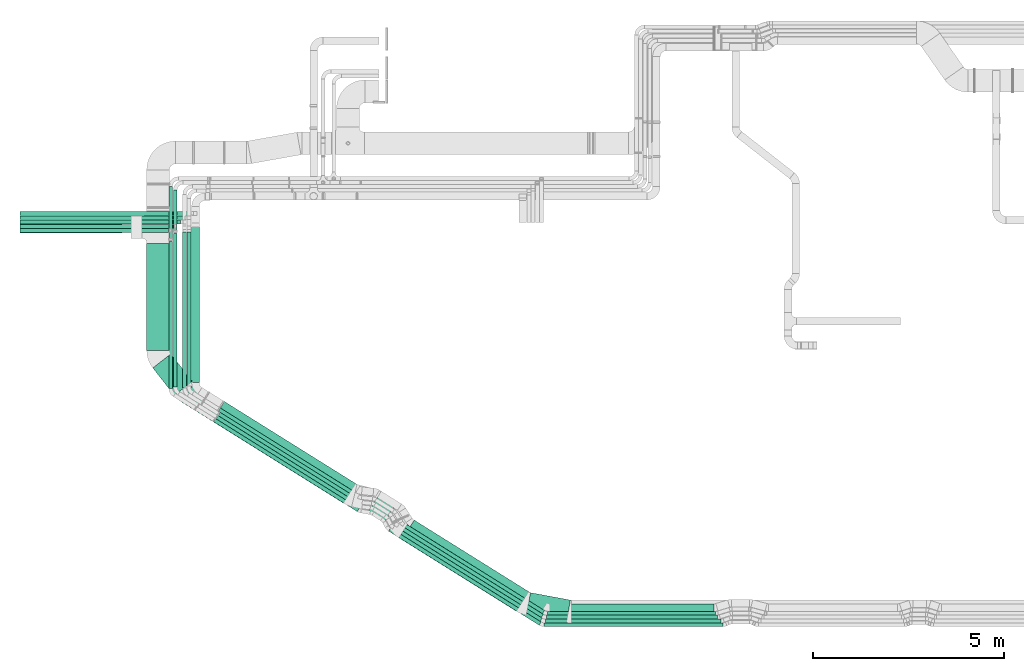
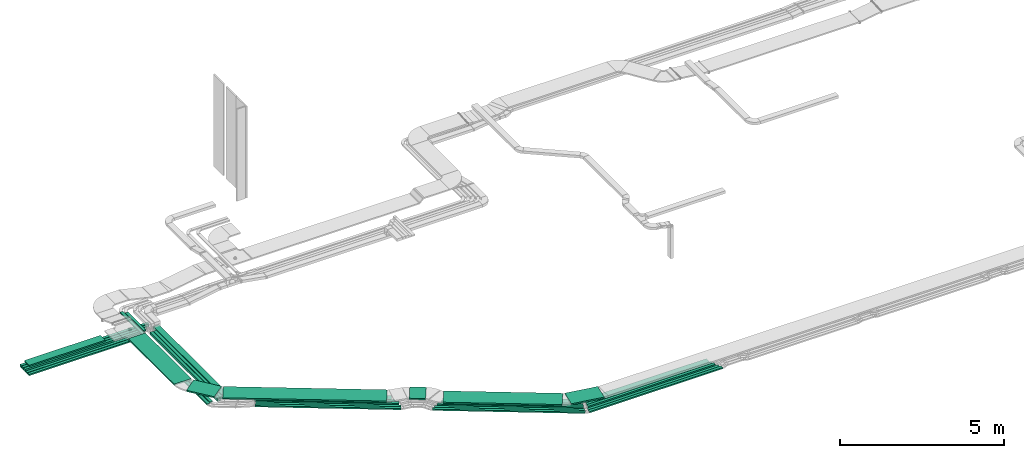
# One storey, part 1 of 28: 34 flow segments.
"""IFC2X3 building model written with IfcOpenShell, lengths in millimetres."""

from ifc_helpers import new_model, entity, si_unit, converted_unit, derived_unit, direction, frame, origin, origin_2d_with_axis, place, context, subcontext, project, spatial, rectangle, extrude, type_object, element, save


model = new_model("IFC2X3")

# Units and contexts
model_context = context("Model", 3, precision=0.01, world=origin(), true_north=direction((6.12303176911189e-17, 1.0)))
body_context = subcontext(model_context, "Body", "Model", "MODEL_VIEW")
ifc_project = project(units=[si_unit("LENGTHUNIT", "METRE", prefix="MILLI"), si_unit("AREAUNIT", "SQUARE_METRE"), si_unit("VOLUMEUNIT", "CUBIC_METRE"), converted_unit("PLANEANGLEUNIT", "DEGREE", entity("IfcRatioMeasure", 0.0174532925199433), si_unit("PLANEANGLEUNIT", "RADIAN"), dimensions=[0, 0, 0, 0, 0, 0, 0]), si_unit("MASSUNIT", "GRAM", prefix="KILO"), derived_unit("MASSDENSITYUNIT", [(si_unit("MASSUNIT", "GRAM", prefix="KILO"), 1), (si_unit("LENGTHUNIT", "METRE"), -3)]), derived_unit("MOMENTOFINERTIAUNIT", [(si_unit("LENGTHUNIT", "METRE"), 4)]), si_unit("TIMEUNIT", "SECOND"), si_unit("FREQUENCYUNIT", "HERTZ"), si_unit("THERMODYNAMICTEMPERATUREUNIT", "DEGREE_CELSIUS"), derived_unit("THERMALTRANSMITTANCEUNIT", [(si_unit("MASSUNIT", "GRAM", prefix="KILO"), 1), (si_unit("THERMODYNAMICTEMPERATUREUNIT", "KELVIN"), -1), (si_unit("TIMEUNIT", "SECOND"), -3)]), derived_unit("VOLUMETRICFLOWRATEUNIT", [(si_unit("LENGTHUNIT", "METRE"), 3), (si_unit("TIMEUNIT", "SECOND"), -1)]), derived_unit("MASSFLOWRATEUNIT", [(si_unit("MASSUNIT", "GRAM", prefix="KILO"), 1), (si_unit("TIMEUNIT", "SECOND"), -1)]), derived_unit("ROTATIONALFREQUENCYUNIT", [(si_unit("TIMEUNIT", "SECOND"), -1)]), si_unit("ELECTRICCURRENTUNIT", "AMPERE"), si_unit("ELECTRICVOLTAGEUNIT", "VOLT"), si_unit("POWERUNIT", "WATT"), si_unit("FORCEUNIT", "NEWTON", prefix="KILO"), si_unit("ILLUMINANCEUNIT", "LUX"), si_unit("LUMINOUSFLUXUNIT", "LUMEN"), si_unit("LUMINOUSINTENSITYUNIT", "CANDELA"), derived_unit("USERDEFINED", [(si_unit("MASSUNIT", "GRAM", prefix="KILO"), -1), (si_unit("LENGTHUNIT", "METRE"), -2), (si_unit("TIMEUNIT", "SECOND"), 3), (si_unit("LUMINOUSFLUXUNIT", "LUMEN"), 1)]), derived_unit("LINEARVELOCITYUNIT", [(si_unit("LENGTHUNIT", "METRE"), 1), (si_unit("TIMEUNIT", "SECOND"), -1)]), si_unit("PRESSUREUNIT", "PASCAL"), derived_unit("USERDEFINED", [(si_unit("LENGTHUNIT", "METRE"), -2), (si_unit("MASSUNIT", "GRAM", prefix="KILO"), 1), (si_unit("TIMEUNIT", "SECOND"), -2)]), derived_unit("LINEARFORCEUNIT", [(si_unit("MASSUNIT", "GRAM", prefix="KILO"), 1), (si_unit("LENGTHUNIT", "METRE"), 1), (si_unit("TIMEUNIT", "SECOND"), -2), (si_unit("LENGTHUNIT", "METRE"), -1)]), derived_unit("PLANARFORCEUNIT", [(si_unit("MASSUNIT", "GRAM", prefix="KILO"), 1), (si_unit("LENGTHUNIT", "METRE"), 1), (si_unit("TIMEUNIT", "SECOND"), -2), (si_unit("LENGTHUNIT", "METRE"), -2)])], contexts=[model_context])

# Site, building, storey
site_placement = place(None, origin())
site = spatial("IfcSite", under=ifc_project, at=site_placement, CompositionType="ELEMENT")
building_placement = place(site_placement, origin())
building = spatial("IfcBuilding", under=site, at=building_placement, CompositionType="ELEMENT")
storey_placement = place(building_placement, frame((0.0, 0.0, 4200.0)))
storey = spatial("IfcBuildingStorey", under=building, at=storey_placement, CompositionType="ELEMENT", Elevation=4200.0)

# Flow segments
cable_carrier_segment_type = type_object("IfcCableCarrierSegmentType", PredefinedType="CABLETRAYSEGMENT")
flow_segment_1_placement = place(storey_placement, frame((6878.59, 10700.79, 2760.0)))
element("IfcFlowSegment", 1, at=flow_segment_1_placement, inside=storey, type_object=cable_carrier_segment_type, context=body_context, shape_type="SweptSolid", body=[
    extrude(rectangle(XDim=4120.0, YDim=99.9999999999989, at=origin_2d_with_axis()), frame((2060.0, 50.0, 0.0), z_axis=(0.0, 0.0, 1.0), x_axis=(-1.0, 0.0, 0.0)), (0.0, 0.0, 1.0), 49.9999999999995),
])
flow_segment_2_placement = place(storey_placement, frame((6878.59, 10590.79, 2760.0)))
element("IfcFlowSegment", 2, at=flow_segment_2_placement, inside=storey, type_object=cable_carrier_segment_type, context=body_context, shape_type="SweptSolid", body=[
    extrude(rectangle(XDim=3894.99999999996, YDim=99.9999999999989, at=origin_2d_with_axis()), frame((1947.5, 50.0, 0.0), z_axis=(0.0, 0.0, 1.0), x_axis=(-1.0, 0.0, 0.0)), (0.0, 0.0, 1.0), 49.9999999999995),
])
flow_segment_3_placement = place(storey_placement, frame((6878.59, 10815.79, 2760.0)))
element("IfcFlowSegment", 3, at=flow_segment_3_placement, inside=storey, type_object=cable_carrier_segment_type, context=body_context, shape_type="SweptSolid", body=[
    extrude(rectangle(XDim=4212.13101413564, YDim=99.9999999999989, at=origin_2d_with_axis()), frame((2106.07, 50.0, 0.0), z_axis=(0.0, 0.0, 1.0), x_axis=(-1.0, 0.0, 0.0)), (0.0, 0.0, 1.0), 99.9999999999989),
])
flow_segment_4_placement = place(storey_placement, frame((10783.59, 6496.14, 2780.0)))
element("IfcFlowSegment", 4, at=flow_segment_4_placement, inside=storey, type_object=cable_carrier_segment_type, context=body_context, shape_type="SweptSolid", body=[
    extrude(rectangle(XDim=3853.03317194815, YDim=99.9999999999989, at=origin_2d_with_axis()), frame((50.0, 1926.52, 0.0), z_axis=(0.0, 0.0, 1.0), x_axis=(0.0, -1.0, 0.0)), (0.0, 0.0, 1.0), 49.9999999999995),
])
flow_segment_5_placement = place(storey_placement, frame((6878.59, 10576.35, 3110.0)))
element("IfcFlowSegment", 5, at=flow_segment_5_placement, inside=storey, type_object=cable_carrier_segment_type, context=body_context, shape_type="SweptSolid", body=[
    extrude(rectangle(XDim=2676.67085236578, YDim=300.000000000001, at=origin_2d_with_axis()), frame((1338.34, 150.0, 0.0), z_axis=(0.0, 0.0, 1.0), x_axis=(-1.0, 0.0, 0.0)), (0.0, 0.0, 1.0), 49.9999999999984),
])
flow_segment_6_placement = place(storey_placement, frame((16923.48, 585.17, 2836.0)))
element("IfcFlowSegment", 6, at=flow_segment_6_placement, inside=storey, type_object=cable_carrier_segment_type, context=body_context, shape_type="SweptSolid", body=[
    extrude(rectangle(XDim=4322.88456665934, YDim=100.000000000004, at=origin_2d_with_axis()), frame((1859.5, 1187.79, 0.0), z_axis=(0.0, 0.0, 1.0), x_axis=(-0.848048096156423, 0.52991926423321, 0.0)), (0.0, 0.0, 1.0), 99.9999999999989),
])
flow_segment_7_placement = place(storey_placement, frame((16819.77, 651.56, 3108.85)))
element("IfcFlowSegment", 7, at=flow_segment_7_placement, inside=storey, type_object=cable_carrier_segment_type, context=body_context, shape_type="SweptSolid", body=[
    extrude(rectangle(XDim=3634.71491749066, YDim=599.999999999996, at=origin_2d_with_axis()), frame((1700.18, 1217.47, 0.0), z_axis=(0.0, 0.0, 1.0), x_axis=(-0.848048096156431, 0.529919264233198, 0.0)), (0.0, 0.0, 1.0), 49.9999999999995),
])
flow_segment_8_placement = place(storey_placement, frame((6878.59, 11042.31, 2760.0)))
element("IfcFlowSegment", 8, at=flow_segment_8_placement, inside=storey, type_object=cable_carrier_segment_type, context=body_context, shape_type="SweptSolid", body=[
    extrude(rectangle(XDim=4489.04753816118, YDim=99.9999999999989, at=origin_2d_with_axis()), frame((2244.52, 50.0, 0.0), z_axis=(0.0, 0.0, 1.0), x_axis=(-1.0, 0.0, 0.0)), (0.0, 0.0, 1.0), 99.9999999999989),
])
flow_segment_9_placement = place(storey_placement, frame((10903.59, 6539.24, 2780.0)))
element("IfcFlowSegment", 9, at=flow_segment_9_placement, inside=storey, type_object=cable_carrier_segment_type, context=body_context, shape_type="SweptSolid", body=[
    extrude(rectangle(XDim=4027.47497293644, YDim=99.9999999999989, at=origin_2d_with_axis()), frame((50.0, 2013.74, 0.0), z_axis=(0.0, 0.0, 1.0), x_axis=(0.0, -1.0, 0.0)), (0.0, 0.0, 1.0), 49.9999999999995),
])
flow_segment_10_placement = place(storey_placement, frame((17117.04, 700.37, 2836.0)))
element("IfcFlowSegment", 10, at=flow_segment_10_placement, inside=storey, type_object=cable_carrier_segment_type, context=body_context, shape_type="SweptSolid", body=[
    extrude(rectangle(XDim=4100.78520796288, YDim=200.000000000001, at=origin_2d_with_axis()), frame((1791.82, 1171.35, 0.0), z_axis=(0.0, 0.0, 1.0), x_axis=(-0.848048096156426, 0.529919264233206, 0.0)), (0.0, 0.0, 1.0), 99.9999999999989),
])
flow_segment_11_placement = place(storey_placement, frame((16773.98, 485.17, 2836.0)))
element("IfcFlowSegment", 11, at=flow_segment_11_placement, inside=storey, type_object=cable_carrier_segment_type, context=body_context, shape_type="SweptSolid", body=[
    extrude(rectangle(XDim=4463.65881740905, YDim=99.9999999999955, at=origin_2d_with_axis()), frame((1919.19, 1225.09, 0.0), z_axis=(0.0, 0.0, 1.0), x_axis=(-0.848048096156426, 0.529919264233206, 0.0)), (0.0, 0.0, 1.0), 99.9999999999989),
])
flow_segment_12_placement = place(storey_placement, frame((16654.15, 385.17, 2836.0)))
element("IfcFlowSegment", 12, at=flow_segment_12_placement, inside=storey, type_object=cable_carrier_segment_type, context=body_context, shape_type="SweptSolid", body=[
    extrude(rectangle(XDim=4568.87946353609, YDim=99.9999999999957, at=origin_2d_with_axis()), frame((1963.81, 1252.97, 0.0), z_axis=(0.0, 0.0, 1.0), x_axis=(-0.848048096156428, 0.529919264233203, 0.0)), (0.0, 0.0, 1.0), 49.9999999999994),
])
flow_segment_13_placement = place(storey_placement, frame((16549.06, 285.17, 2836.0)))
element("IfcFlowSegment", 13, at=flow_segment_13_placement, inside=storey, type_object=cable_carrier_segment_type, context=body_context, shape_type="SweptSolid", body=[
    extrude(rectangle(XDim=4658.67624033948, YDim=99.9999999999955, at=origin_2d_with_axis()), frame((2001.89, 1276.76, 0.0), z_axis=(0.0, 0.0, 1.0), x_axis=(-0.848048096156427, 0.529919264233204, 0.0)), (0.0, 0.0, 1.0), 49.9999999999995),
])
flow_segment_14_placement = place(storey_placement, frame((20164.36, 354.48, 3108.85)))
element("IfcFlowSegment", 14, at=flow_segment_14_placement, inside=storey, type_object=cable_carrier_segment_type, context=body_context, shape_type="SweptSolid", body=[
    extrude(rectangle(XDim=1067.06528774332, YDim=600.0, at=origin_2d_with_axis()), frame((579.38, 392.47, 0.0), z_axis=(0.0, 0.0, 1.0), x_axis=(0.983152914728378, -0.182784972744192, 0.0)), (0.0, 0.0, 1.0), 49.9999999999995),
])
flow_segment_15_placement = place(storey_placement, frame((11122.76, 3489.34, 3108.85)))
element("IfcFlowSegment", 15, at=flow_segment_15_placement, inside=storey, type_object=cable_carrier_segment_type, context=body_context, shape_type="SweptSolid", body=[
    extrude(rectangle(XDim=4997.38894305518, YDim=600.0, at=origin_2d_with_axis()), frame((2277.99, 1578.52, 0.0), z_axis=(0.0, 0.0, 1.0), x_axis=(-0.84804809615643, 0.529919264233199, 0.0)), (0.0, 0.0, 1.0), 49.9999999999994),
])
flow_segment_16_placement = place(storey_placement, frame((16031.14, 3009.48, 3108.85)))
element("IfcFlowSegment", 16, at=flow_segment_16_placement, inside=storey, type_object=cable_carrier_segment_type, context=body_context, shape_type="SweptSolid", body=[
    extrude(rectangle(XDim=503.262588776523, YDim=600.000000000001, at=origin_2d_with_axis()), frame((372.37, 387.76, 0.0), z_axis=(0.0, 0.0, 1.0), x_axis=(0.848048096156357, -0.529919264233315, 0.0)), (0.0, 0.0, 1.0), 49.9999999999994),
])
flow_segment_17_placement = place(storey_placement, frame((20634.17, 246.66, 2836.0)))
element("IfcFlowSegment", 17, at=flow_segment_17_placement, inside=storey, type_object=cable_carrier_segment_type, context=body_context, shape_type="SweptSolid", body=[
    extrude(rectangle(XDim=4688.05213494792, YDim=100.0, at=origin_2d_with_axis()), frame((2344.03, 50.0, 0.0)), (0.0, 0.0, 1.0), 49.9999999999995),
])
flow_segment_18_placement = place(storey_placement, frame((20663.11, 346.66, 2836.0)))
element("IfcFlowSegment", 18, at=flow_segment_18_placement, inside=storey, type_object=cable_carrier_segment_type, context=body_context, shape_type="SweptSolid", body=[
    extrude(rectangle(XDim=4608.58311386195, YDim=100.0, at=origin_2d_with_axis()), frame((2304.29, 50.0, 0.0)), (0.0, 0.0, 1.0), 49.9999999999995),
])
flow_segment_19_placement = place(storey_placement, frame((20693.71, 446.66, 2836.0)))
element("IfcFlowSegment", 19, at=flow_segment_19_placement, inside=storey, type_object=cable_carrier_segment_type, context=body_context, shape_type="SweptSolid", body=[
    extrude(rectangle(XDim=4490.76072257844, YDim=100.0, at=origin_2d_with_axis()), frame((2245.38, 50.0, 0.0)), (0.0, 0.0, 1.0), 99.9999999999989),
])
flow_segment_20_placement = place(storey_placement, frame((20723.82, 546.66, 2836.0)))
element("IfcFlowSegment", 20, at=flow_segment_20_placement, inside=storey, type_object=cable_carrier_segment_type, context=body_context, shape_type="SweptSolid", body=[
    extrude(rectangle(XDim=4410.76072257844, YDim=99.9999999999999, at=origin_2d_with_axis()), frame((2205.38, 50.0, 0.0)), (0.0, 0.0, 1.0), 99.9999999999978),
])
flow_segment_21_placement = place(storey_placement, frame((20782.02, 646.66, 2836.0)))
element("IfcFlowSegment", 21, at=flow_segment_21_placement, inside=storey, type_object=cable_carrier_segment_type, context=body_context, shape_type="SweptSolid", body=[
    extrude(rectangle(XDim=4308.95090322303, YDim=200.0, at=origin_2d_with_axis()), frame((2154.48, 100.0, 0.0)), (0.0, 0.0, 1.0), 99.9999999999989),
])
flow_segment_22_placement = place(storey_placement, frame((11263.59, 6562.98, 2779.59)))
element("IfcFlowSegment", 22, at=flow_segment_22_placement, inside=storey, type_object=cable_carrier_segment_type, context=body_context, shape_type="SweptSolid", body=[
    extrude(rectangle(XDim=4044.05301703725, YDim=99.9999999999989, at=origin_2d_with_axis()), frame((50.0, 2022.03, 0.2), z_axis=(0.0, 9.78889981381199e-05, 0.999999995208872), x_axis=(0.0, -0.999999995208872, 9.78889981381199e-05)), (0.0, 0.0, 1.0), 99.9999999999993),
])
flow_segment_23_placement = place(storey_placement, frame((11954.61, 3265.39, 2836.0)))
element("IfcFlowSegment", 23, at=flow_segment_23_placement, inside=storey, type_object=cable_carrier_segment_type, context=body_context, shape_type="SweptSolid", body=[
    extrude(rectangle(XDim=4452.45175223541, YDim=99.9999999999997, at=origin_2d_with_axis()), frame((1914.44, 1222.12, 0.0), z_axis=(0.0, 0.0, 1.0), x_axis=(-0.848048096156423, 0.529919264233209, 0.0)), (0.0, 0.0, 1.0), 49.9999999999994),
])
flow_segment_24_placement = place(storey_placement, frame((12023.56, 3351.05, 2836.0)))
element("IfcFlowSegment", 24, at=flow_segment_24_placement, inside=storey, type_object=cable_carrier_segment_type, context=body_context, shape_type="SweptSolid", body=[
    extrude(rectangle(XDim=4432.32781406283, YDim=99.9999999999997, at=origin_2d_with_axis()), frame((1905.91, 1216.79, 0.0), z_axis=(0.0, 0.0, 1.0), x_axis=(-0.848048096156423, 0.52991926423321, 0.0)), (0.0, 0.0, 1.0), 49.9999999999994),
])
flow_segment_25_placement = place(storey_placement, frame((12079.59, 3468.51, 2836.0)))
element("IfcFlowSegment", 25, at=flow_segment_25_placement, inside=storey, type_object=cable_carrier_segment_type, context=body_context, shape_type="SweptSolid", body=[
    extrude(rectangle(XDim=4369.38416435489, YDim=99.9999999999997, at=origin_2d_with_axis()), frame((1879.22, 1200.11, 0.0), z_axis=(0.0, 0.0, 1.0), x_axis=(-0.848048096156423, 0.52991926423321, 0.0)), (0.0, 0.0, 1.0), 99.9999999999989),
])
flow_segment_26_placement = place(storey_placement, frame((12082.69, 3621.27, 2836.0)))
element("IfcFlowSegment", 26, at=flow_segment_26_placement, inside=storey, type_object=cable_carrier_segment_type, context=body_context, shape_type="SweptSolid", body=[
    extrude(rectangle(XDim=4301.68405393387, YDim=99.9999999999992, at=origin_2d_with_axis()), frame((1850.51, 1182.18, 0.0), z_axis=(0.0, 0.0, 1.0), x_axis=(-0.84804809615642, 0.529919264233215, 0.0)), (0.0, 0.0, 1.0), 99.9999999999989),
])
flow_segment_27_placement = place(storey_placement, frame((12135.92, 3765.54, 2836.0)))
element("IfcFlowSegment", 27, at=flow_segment_27_placement, inside=storey, type_object=cable_carrier_segment_type, context=body_context, shape_type="SweptSolid", body=[
    extrude(rectangle(XDim=4190.18160100393, YDim=199.999999999998, at=origin_2d_with_axis()), frame((1829.73, 1195.03, 0.0), z_axis=(0.0, 0.0, 1.0), x_axis=(-0.848048096156421, 0.529919264233213, 0.0)), (0.0, 0.0, 1.0), 100.000000000001),
])
flow_segment_28_placement = place(storey_placement, frame((11383.59, 6651.12, 2780.0)))
element("IfcFlowSegment", 28, at=flow_segment_28_placement, inside=storey, type_object=cable_carrier_segment_type, context=body_context, shape_type="SweptSolid", body=[
    extrude(rectangle(XDim=4180.42273713681, YDim=200.000000000002, at=origin_2d_with_axis()), frame((100.0, 2090.21, 0.0), z_axis=(0.0, 0.0, 1.0), x_axis=(0.0, 1.0, 0.0)), (0.0, 0.0, 1.0), 99.9999999999989),
])
flow_segment_29_placement = place(storey_placement, frame((10203.59, 7499.26, 3108.85)))
element("IfcFlowSegment", 29, at=flow_segment_29_placement, inside=storey, type_object=cable_carrier_segment_type, context=body_context, shape_type="SweptSolid", body=[
    extrude(rectangle(XDim=2797.08856913082, YDim=600.000000000002, at=origin_2d_with_axis()), frame((300.0, 1398.54, 0.0), z_axis=(0.0, 0.0, 1.0), x_axis=(0.0, -1.0, 0.0)), (0.0, 0.0, 1.0), 49.9999999999995),
])
flow_segment_30_placement = place(storey_placement, frame((10363.2, 6313.16, 3108.85)))
element("IfcFlowSegment", 30, at=flow_segment_30_placement, inside=storey, type_object=cable_carrier_segment_type, context=body_context, shape_type="SweptSolid", body=[
    extrude(rectangle(XDim=916.95422892756, YDim=600.000000000001, at=origin_2d_with_axis()), frame((518.67, 545.98, 0.0), z_axis=(0.0, 0.0, 1.0), x_axis=(0.615661475325661, -0.78801075360672, 0.0)), (0.0, 0.0, 1.0), 49.9999999999995),
])
flow_segment_31_placement = place(storey_placement, frame((6878.59, 10928.65, 2760.0)))
element("IfcFlowSegment", 31, at=flow_segment_31_placement, inside=storey, type_object=cable_carrier_segment_type, context=body_context, shape_type="SweptSolid", body=[
    extrude(rectangle(XDim=4324.99999999995, YDim=99.9999999999989, at=origin_2d_with_axis()), frame((2162.5, 50.0, 0.0)), (0.0, 0.0, 1.0), 100.000000000001),
])
flow_segment_32_placement = place(storey_placement, frame((11148.59, 6505.27, 2780.0)))
element("IfcFlowSegment", 32, at=flow_segment_32_placement, inside=storey, type_object=cable_carrier_segment_type, context=body_context, shape_type="SweptSolid", body=[
    extrude(rectangle(XDim=4101.77848929623, YDim=99.9999999999989, at=origin_2d_with_axis()), frame((50.0, 2050.89, 0.0), z_axis=(0.0, 0.0, 1.0), x_axis=(0.0, -1.0, 0.0)), (0.0, 0.0, 1.0), 99.9999999999989),
])
flow_segment_33_placement = place(storey_placement, frame((10903.59, 10608.79, 2975.0)))
element("IfcFlowSegment", 33, at=flow_segment_33_placement, inside=storey, type_object=cable_carrier_segment_type, context=body_context, shape_type="SweptSolid", body=[
    extrude(rectangle(XDim=1091.74419399839, YDim=99.9999999999989, at=origin_2d_with_axis()), frame((50.0, 545.87, 0.0), z_axis=(0.0, 0.0, 1.0), x_axis=(0.0, -1.0, 0.0)), (0.0, 0.0, 1.0), 49.9999999999995),
])
flow_segment_34_placement = place(storey_placement, frame((10783.59, 10384.03, 2975.0)))
element("IfcFlowSegment", 34, at=flow_segment_34_placement, inside=storey, type_object=cable_carrier_segment_type, context=body_context, shape_type="SweptSolid", body=[
    extrude(rectangle(XDim=1419.00000000001, YDim=99.9999999999989, at=origin_2d_with_axis()), frame((50.0, 709.5, 0.0), z_axis=(0.0, 0.0, 1.0), x_axis=(0.0, -1.0, 0.0)), (0.0, 0.0, 1.0), 49.9999999999995),
])

save(model, "model.ifc")
